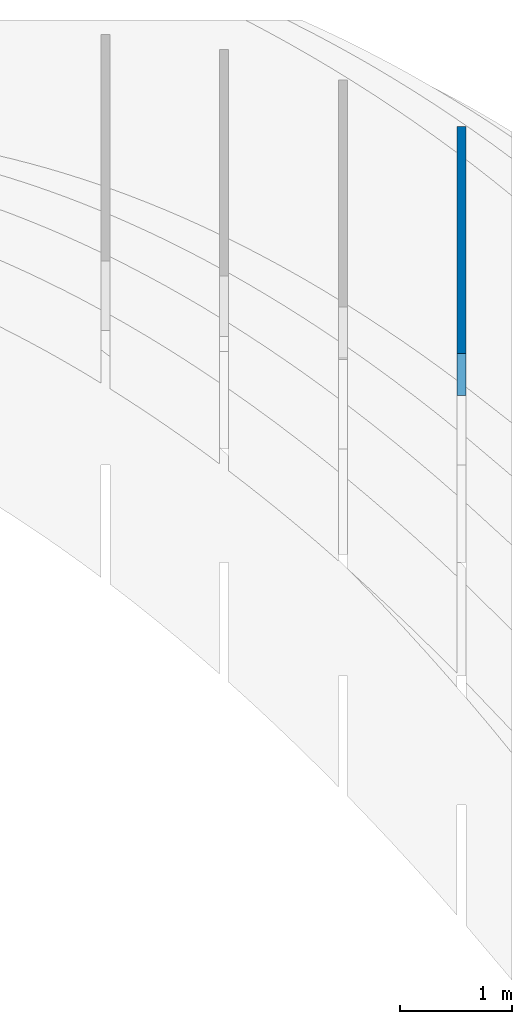
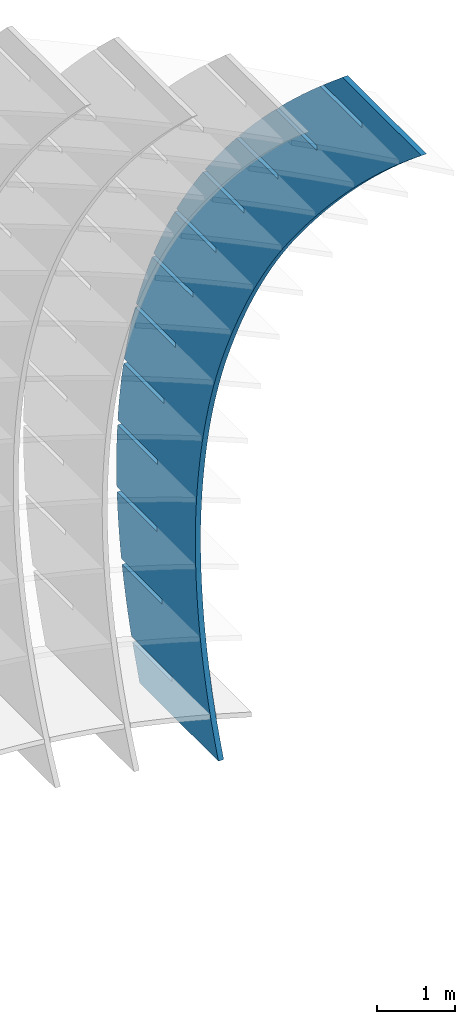
# Not in any storey, part 9 of 9: 1 wall.
"""IFC2X3 building model written with IfcOpenShell, lengths in metres."""

from ifc_helpers import new_model, entity, si_unit, direction, frame, origin_with_axes, place, context, project, spatial, extrude, material, type_object, element, save


model = new_model("IFC2X3")

# Units and contexts
model_context = context("Model", 3, precision=2.54e-06, world=origin_with_axes(), true_north=direction((0.0, 1.0)), identifier="Body")
ifc_project = project(units=[si_unit("LENGTHUNIT", "METRE"), si_unit("AREAUNIT", "SQUARE_METRE"), si_unit("VOLUMEUNIT", "CUBIC_METRE"), si_unit("PLANEANGLEUNIT", "RADIAN")], contexts=[model_context])

# Building
building_placement = place(None, origin_with_axes())
building = spatial("IfcBuilding", under=ifc_project, at=building_placement, Name="Building", CompositionType="ELEMENT")

# Wall
ifc_material = material(Name="MATERIAL")
wall_type = type_object("IfcWallType", Name="WALL", PredefinedType="NOTDEFINED", material=ifc_material)
wall_placement = place(None, origin_with_axes())
cartesian_point_1 = entity("IfcCartesianPoint", [3.28769159298477, 0.668743869063012])
cartesian_point_2 = entity("IfcCartesianPoint", [5.87221337028232, 2.41770733062886])
cartesian_point_3 = entity("IfcCartesianPoint", [8.02403170529212, 5.2541811588839])
cartesian_point_4 = entity("IfcCartesianPoint", [9.86737523397391, 9.55299435379442])
cartesian_point_5 = entity("IfcCartesianPoint", [10.6185964879454, 7.66495552273574])
cartesian_point_6 = entity("IfcCartesianPoint", [10.4166196479034, 7.06276652656811])
cartesian_point_7 = entity("IfcCartesianPoint", [10.0508172299027, 7.98213504287184])
cartesian_point_8 = entity("IfcCartesianPoint", [9.97765572519925, 7.95302521928043])
cartesian_point_9 = entity("IfcCartesianPoint", [10.3770877152857, 6.94913574775335])
cartesian_point_10 = entity("IfcCartesianPoint", [9.85904449576732, 5.59098985593508])
cartesian_point_11 = entity("IfcCartesianPoint", [9.49129082830915, 6.5152624330932])
cartesian_point_12 = entity("IfcCartesianPoint", [9.41812932360567, 6.48615260950179])
cartesian_point_13 = entity("IfcCartesianPoint", [9.81561011626891, 5.48716706805194])
cartesian_point_14 = entity("IfcCartesianPoint", [9.24879977321851, 4.25158722774034])
cartesian_point_15 = entity("IfcCartesianPoint", [8.87909839392739, 5.18075497466789])
cartesian_point_16 = entity("IfcCartesianPoint", [8.80593688922391, 5.15164515107648])
cartesian_point_17 = entity("IfcCartesianPoint", [9.20146997005414, 4.15755477939588])
cartesian_point_18 = entity("IfcCartesianPoint", [8.58600681353276, 3.0442536959601])
cartesian_point_19 = entity("IfcCartesianPoint", [8.2143577224083, 3.97831661265638])
cartesian_point_20 = entity("IfcCartesianPoint", [8.14119621770482, 3.94920678906497])
cartesian_point_21 = entity("IfcCartesianPoint", [8.53478158670202, 2.96001158715363])
cartesian_point_22 = entity("IfcCartesianPoint", [7.87066561670875, 1.96898926059224])
cartesian_point_23 = entity("IfcCartesianPoint", [7.49706881375187, 2.90794734705868])
cartesian_point_24 = entity("IfcCartesianPoint", [7.42390730904839, 2.87883752346727])
cartesian_point_25 = entity("IfcCartesianPoint", [7.81554496621256, 1.89453749132518])
cartesian_point_26 = entity("IfcCartesianPoint", [7.10277618274845, 1.02579392163966])
cartesian_point_27 = entity("IfcCartesianPoint", [6.72723166795809, 1.96964717787479])
cartesian_point_28 = entity("IfcCartesianPoint", [6.65407016325462, 1.94053735428338])
cartesian_point_29 = entity("IfcCartesianPoint", [7.04376010858576, 0.961132491910532])
cartesian_point_30 = entity("IfcCartesianPoint", [6.28233851165028, 0.21466767910021])
cartesian_point_31 = entity("IfcCartesianPoint", [5.90484628502699, 1.1634161051047])
cartesian_point_32 = entity("IfcCartesianPoint", [5.83168478032351, 1.13430628151329])
cartesian_point_33 = entity("IfcCartesianPoint", [6.21942701382163, 0.159796588909695])
cartesian_point_34 = entity("IfcCartesianPoint", [5.40935260341485, -0.464389467025337])
cartesian_point_35 = entity("IfcCartesianPoint", [5.02991266495853, 0.489254128748418])
cartesian_point_36 = entity("IfcCartesianPoint", [4.95675116025506, 0.460144305157008])
cartesian_point_37 = entity("IfcCartesianPoint", [5.34254568192015, -0.509470217677336])
cartesian_point_38 = entity("IfcCartesianPoint", [4.48381845804198, -1.01137751673713])
cartesian_point_39 = entity("IfcCartesianPoint", [4.10243080775275, -0.0528387511940572])
cartesian_point_40 = entity("IfcCartesianPoint", [4.02926930304927, -0.0819485747854675])
cartesian_point_41 = entity("IfcCartesianPoint", [4.41311611288134, -1.04666792785056])
cartesian_point_42 = entity("IfcCartesianPoint", [3.50573607553196, -1.42629647003502])
cartesian_point_43 = entity("IfcCartesianPoint", [3.12240071340962, -0.462862534722727])
cartesian_point_44 = entity("IfcCartesianPoint", [3.04923920870614, -0.491972358314137])
cartesian_point_45 = entity("IfcCartesianPoint", [3.43113830670519, -1.45179654160998])
cartesian_point_46 = entity("IfcCartesianPoint", [2.47510545588443, -1.70914632691916])
cartesian_point_47 = entity("IfcCartesianPoint", [2.08982238192915, -0.740817221837592])
cartesian_point_48 = entity("IfcCartesianPoint", [2.01666087722568, -0.769927045429])
cartesian_point_49 = entity("IfcCartesianPoint", [2.3966122633917, -1.72485605895559])
cartesian_point_50 = entity("IfcCartesianPoint", [1.39187885792397, -1.85980709984498])
cartesian_point_51 = entity("IfcCartesianPoint", [1.00462100586319, -0.886514799531499])
cartesian_point_52 = entity("IfcCartesianPoint", [0.931459501159708, -0.915624623122909])
cartesian_point_53 = entity("IfcCartesianPoint", [1.30943856211226, -1.86559660625292])
cartesian_point_54 = entity("IfcCartesianPoint", [0.751221253971776, -1.88803883105749])
element("IfcWall", 1, at=wall_placement, inside=building, type_object=wall_type, context=model_context, shape_type="SweptSolid", body=[
    extrude(entity("IfcArbitraryOpenProfileDef", "AREA", None, entity("IfcCompositeCurve", [entity("IfcCompositeCurveSegment", "CONTINUOUS", True, entity("IfcTrimmedCurve", entity("IfcCircle", entity("IfcAxis2Placement2D", entity("IfcCartesianPoint", [0.0, 8.41587855509109]), entity("IfcDirection", [0.0, -1.0])), 8.41587855509109), [entity("IfcParameterValue", 0.0), entity("IfcCartesianPoint", [0.0, -8.41587855509109])], [entity("IfcParameterValue", 0.401341291089857), cartesian_point_1], True, "PARAMETER")), entity("IfcCompositeCurveSegment", "CONTINUOUS", True, entity("IfcTrimmedCurve", entity("IfcCircle", entity("IfcAxis2Placement2D", entity("IfcCartesianPoint", [-0.152455611471072, 8.53651736635181]), entity("IfcDirection", [0.40062297, -0.916243])), 8.58699438645242), [entity("IfcParameterValue", 0.0), cartesian_point_1], [entity("IfcParameterValue", 0.365449258808833), cartesian_point_2], True, "PARAMETER")), entity("IfcCompositeCurveSegment", "CONTINUOUS", True, entity("IfcTrimmedCurve", entity("IfcCircle", entity("IfcAxis2Placement2D", entity("IfcCartesianPoint", [-3.06231922363268, 11.4301098983216]), entity("IfcDirection", [0.70403209, -0.71016816])), 12.6905190088461), [entity("IfcParameterValue", 0.0), cartesian_point_2], [entity("IfcParameterValue", 0.281478210863649), cartesian_point_3], True, "PARAMETER")), entity("IfcCompositeCurveSegment", "CONTINUOUS", True, entity("IfcTrimmedCurve", entity("IfcCircle", entity("IfcAxis2Placement2D", entity("IfcCartesianPoint", [-11.5888974246578, 16.2088839988855]), entity("IfcDirection", [0.87304703, -0.48763602])), 22.4649171680907), [entity("IfcParameterValue", 0.0), cartesian_point_3], [entity("IfcParameterValue", 0.208585299590096), cartesian_point_4], True, "PARAMETER")), entity("IfcCompositeCurveSegment", "CONTINUOUS", True, entity("IfcPolyline", [cartesian_point_4, cartesian_point_5])), entity("IfcCompositeCurveSegment", "CONTINUOUS", True, entity("IfcPolyline", [cartesian_point_5, cartesian_point_6])), entity("IfcCompositeCurveSegment", "CONTINUOUS", True, entity("IfcPolyline", [cartesian_point_6, cartesian_point_7])), entity("IfcCompositeCurveSegment", "CONTINUOUS", True, entity("IfcPolyline", [cartesian_point_7, cartesian_point_8])), entity("IfcCompositeCurveSegment", "CONTINUOUS", True, entity("IfcPolyline", [cartesian_point_8, cartesian_point_9])), entity("IfcCompositeCurveSegment", "CONTINUOUS", True, entity("IfcTrimmedCurve", entity("IfcCircle", entity("IfcAxis2Placement2D", entity("IfcCartesianPoint", [-13.5680050144791, 15.3047391312929]), entity("IfcDirection", [0.92374079, -0.38301821])), 25.3610641287004), [entity("IfcParameterValue", 0.057323730803991), cartesian_point_9], [entity("IfcParameterValue", 0.0), cartesian_point_10], False, "PARAMETER")), entity("IfcCompositeCurveSegment", "CONTINUOUS", True, entity("IfcPolyline", [cartesian_point_10, cartesian_point_11])), entity("IfcCompositeCurveSegment", "CONTINUOUS", True, entity("IfcPolyline", [cartesian_point_11, cartesian_point_12])), entity("IfcCompositeCurveSegment", "CONTINUOUS", True, entity("IfcPolyline", [cartesian_point_12, cartesian_point_13])), entity("IfcCompositeCurveSegment", "CONTINUOUS", True, entity("IfcTrimmedCurve", entity("IfcCircle", entity("IfcAxis2Placement2D", entity("IfcCartesianPoint", [-9.51258898905638, 13.6059928086204]), entity("IfcDirection", [0.89492822, -0.44621012])), 20.9641267898478), [entity("IfcParameterValue", 0.0648548221772766), cartesian_point_13], [entity("IfcParameterValue", 0.0), cartesian_point_14], False, "PARAMETER")), entity("IfcCompositeCurveSegment", "CONTINUOUS", True, entity("IfcPolyline", [cartesian_point_14, cartesian_point_15])), entity("IfcCompositeCurveSegment", "CONTINUOUS", True, entity("IfcPolyline", [cartesian_point_15, cartesian_point_16])), entity("IfcCompositeCurveSegment", "CONTINUOUS", True, entity("IfcPolyline", [cartesian_point_16, cartesian_point_17])), entity("IfcCompositeCurveSegment", "CONTINUOUS", True, entity("IfcTrimmedCurve", entity("IfcCircle", entity("IfcAxis2Placement2D", entity("IfcCartesianPoint", [-6.13223550567278, 11.9076717979881]), entity("IfcDirection", [0.85665796, -0.51588481])), 17.1810022239161), [entity("IfcParameterValue", 0.0740579088368195), cartesian_point_17], [entity("IfcParameterValue", 0.0), cartesian_point_18], False, "PARAMETER")), entity("IfcCompositeCurveSegment", "CONTINUOUS", True, entity("IfcPolyline", [cartesian_point_18, cartesian_point_19])), entity("IfcCompositeCurveSegment", "CONTINUOUS", True, entity("IfcPolyline", [cartesian_point_19, cartesian_point_20])), entity("IfcCompositeCurveSegment", "CONTINUOUS", True, entity("IfcPolyline", [cartesian_point_20, cartesian_point_21])), entity("IfcCompositeCurveSegment", "CONTINUOUS", True, entity("IfcTrimmedCurve", entity("IfcCircle", entity("IfcAxis2Placement2D", entity("IfcCartesianPoint", [-3.55968600299358, 10.3468698263739]), entity("IfcDirection", [0.80655227, -0.59116279])), 14.1718672349318), [entity("IfcParameterValue", 0.0842035553852847), cartesian_point_21], [entity("IfcParameterValue", 0.0), cartesian_point_22], False, "PARAMETER")), entity("IfcCompositeCurveSegment", "CONTINUOUS", True, entity("IfcPolyline", [cartesian_point_22, cartesian_point_23])), entity("IfcCompositeCurveSegment", "CONTINUOUS", True, entity("IfcPolyline", [cartesian_point_23, cartesian_point_24])), entity("IfcCompositeCurveSegment", "CONTINUOUS", True, entity("IfcPolyline", [cartesian_point_24, cartesian_point_25])), entity("IfcCompositeCurveSegment", "CONTINUOUS", True, entity("IfcTrimmedCurve", entity("IfcCircle", entity("IfcAxis2Placement2D", entity("IfcCartesianPoint", [-1.68890100288095, 8.96577835108721]), entity("IfcDirection", [0.74213981, -0.6702451])), 11.8463893434323), [entity("IfcParameterValue", 0.0948934985891402), cartesian_point_25], [entity("IfcParameterValue", 0.0), cartesian_point_26], False, "PARAMETER")), entity("IfcCompositeCurveSegment", "CONTINUOUS", True, entity("IfcPolyline", [cartesian_point_26, cartesian_point_27])), entity("IfcCompositeCurveSegment", "CONTINUOUS", True, entity("IfcPolyline", [cartesian_point_27, cartesian_point_28])), entity("IfcCompositeCurveSegment", "CONTINUOUS", True, entity("IfcPolyline", [cartesian_point_28, cartesian_point_29])), entity("IfcCompositeCurveSegment", "CONTINUOUS", True, entity("IfcTrimmedCurve", entity("IfcCircle", entity("IfcAxis2Placement2D", entity("IfcCartesianPoint", [-0.413841027195036, 7.80658882943607]), entity("IfcDirection", [0.66147864, -0.74996401])), 10.1230473262436), [entity("IfcParameterValue", 0.10538157879389), cartesian_point_29], [entity("IfcParameterValue", 0.0), cartesian_point_30], False, "PARAMETER")), entity("IfcCompositeCurveSegment", "CONTINUOUS", True, entity("IfcPolyline", [cartesian_point_30, cartesian_point_31])), entity("IfcCompositeCurveSegment", "CONTINUOUS", True, entity("IfcPolyline", [cartesian_point_31, cartesian_point_32])), entity("IfcCompositeCurveSegment", "CONTINUOUS", True, entity("IfcPolyline", [cartesian_point_32, cartesian_point_33])), entity("IfcCompositeCurveSegment", "CONTINUOUS", True, entity("IfcTrimmedCurve", entity("IfcCircle", entity("IfcAxis2Placement2D", entity("IfcCartesianPoint", [0.371533402202206, 6.91149271872993]), entity("IfcDirection", [0.56400985, -0.82576806])), 8.93214757615708), [entity("IfcParameterValue", 0.114554431580332), cartesian_point_33], [entity("IfcParameterValue", 0.0), cartesian_point_34], False, "PARAMETER")), entity("IfcCompositeCurveSegment", "CONTINUOUS", True, entity("IfcPolyline", [cartesian_point_34, cartesian_point_35])), entity("IfcCompositeCurveSegment", "CONTINUOUS", True, entity("IfcPolyline", [cartesian_point_35, cartesian_point_36])), entity("IfcCompositeCurveSegment", "CONTINUOUS", True, entity("IfcPolyline", [cartesian_point_36, cartesian_point_37])), entity("IfcCompositeCurveSegment", "CONTINUOUS", True, entity("IfcTrimmedCurve", entity("IfcCircle", entity("IfcAxis2Placement2D", entity("IfcCartesianPoint", [0.773261763449901, 6.32268147627733]), entity("IfcDirection", [0.45144517, -0.89229886])), 8.21928538845066), [entity("IfcParameterValue", 0.12108781188062), cartesian_point_37], [entity("IfcParameterValue", 0.0), cartesian_point_38], False, "PARAMETER")), entity("IfcCompositeCurveSegment", "CONTINUOUS", True, entity("IfcPolyline", [cartesian_point_38, cartesian_point_39])), entity("IfcCompositeCurveSegment", "CONTINUOUS", True, entity("IfcPolyline", [cartesian_point_39, cartesian_point_40])), entity("IfcCompositeCurveSegment", "CONTINUOUS", True, entity("IfcPolyline", [cartesian_point_40, cartesian_point_41])), entity("IfcCompositeCurveSegment", "CONTINUOUS", True, entity("IfcTrimmedCurve", entity("IfcCircle", entity("IfcAxis2Placement2D", entity("IfcCartesianPoint", [0.897383534686859, 6.08234655938701]), entity("IfcDirection", [0.32814471, -0.94462747])), 7.94878752519032), [entity("IfcParameterValue", 0.123820419877383), cartesian_point_41], [entity("IfcParameterValue", 0.0), cartesian_point_42], False, "PARAMETER")), entity("IfcCompositeCurveSegment", "CONTINUOUS", True, entity("IfcPolyline", [cartesian_point_42, cartesian_point_43])), entity("IfcCompositeCurveSegment", "CONTINUOUS", True, entity("IfcPolyline", [cartesian_point_43, cartesian_point_44])), entity("IfcCompositeCurveSegment", "CONTINUOUS", True, entity("IfcPolyline", [cartesian_point_44, cartesian_point_45])), entity("IfcCompositeCurveSegment", "CONTINUOUS", True, entity("IfcTrimmedCurve", entity("IfcCircle", entity("IfcAxis2Placement2D", entity("IfcCartesianPoint", [0.849938194051893, 6.23267942536748]), entity("IfcDirection", [0.20047946, -0.9796979])), 8.10640271073523), [entity("IfcParameterValue", 0.122209681178169), cartesian_point_45], [entity("IfcParameterValue", 0.0), cartesian_point_46], False, "PARAMETER")), entity("IfcCompositeCurveSegment", "CONTINUOUS", True, entity("IfcPolyline", [cartesian_point_46, cartesian_point_47])), entity("IfcCompositeCurveSegment", "CONTINUOUS", True, entity("IfcPolyline", [cartesian_point_47, cartesian_point_48])), entity("IfcCompositeCurveSegment", "CONTINUOUS", True, entity("IfcPolyline", [cartesian_point_48, cartesian_point_49])), entity("IfcCompositeCurveSegment", "CONTINUOUS", True, entity("IfcTrimmedCurve", entity("IfcCircle", entity("IfcAxis2Placement2D", entity("IfcCartesianPoint", [0.742843376466313, 6.78005311627586]), entity("IfcDirection", [0.07491, -0.9971903])), 8.6642040378963), [entity("IfcParameterValue", 0.117071925679641), cartesian_point_49], [entity("IfcParameterValue", 0.0), cartesian_point_50], False, "PARAMETER")), entity("IfcCompositeCurveSegment", "CONTINUOUS", True, entity("IfcPolyline", [cartesian_point_50, cartesian_point_51])), entity("IfcCompositeCurveSegment", "CONTINUOUS", True, entity("IfcPolyline", [cartesian_point_51, cartesian_point_52])), entity("IfcCompositeCurveSegment", "CONTINUOUS", True, entity("IfcPolyline", [cartesian_point_52, cartesian_point_53])), entity("IfcCompositeCurveSegment", "CONTINUOUS", True, entity("IfcPolyline", [cartesian_point_53, cartesian_point_54])), entity("IfcCompositeCurveSegment", "CONTINUOUS", True, entity("IfcPolyline", [cartesian_point_54, entity("IfcCartesianPoint", [0.0, 0.0])]))], "UNKNOWN")), frame((18.3985655316391, -0.926525869501522, -6.51240052652882), z_axis=(1.0, 0.0, 0.0), x_axis=(0.0, 0.3696955, 0.92915297)), (0.0, 0.0, 1.0), 0.07874),
])

save(model, "model.ifc")
